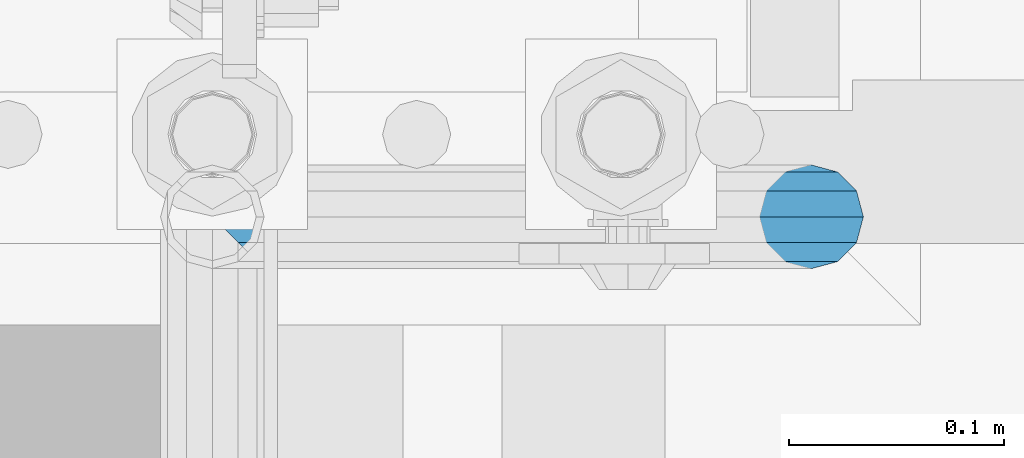
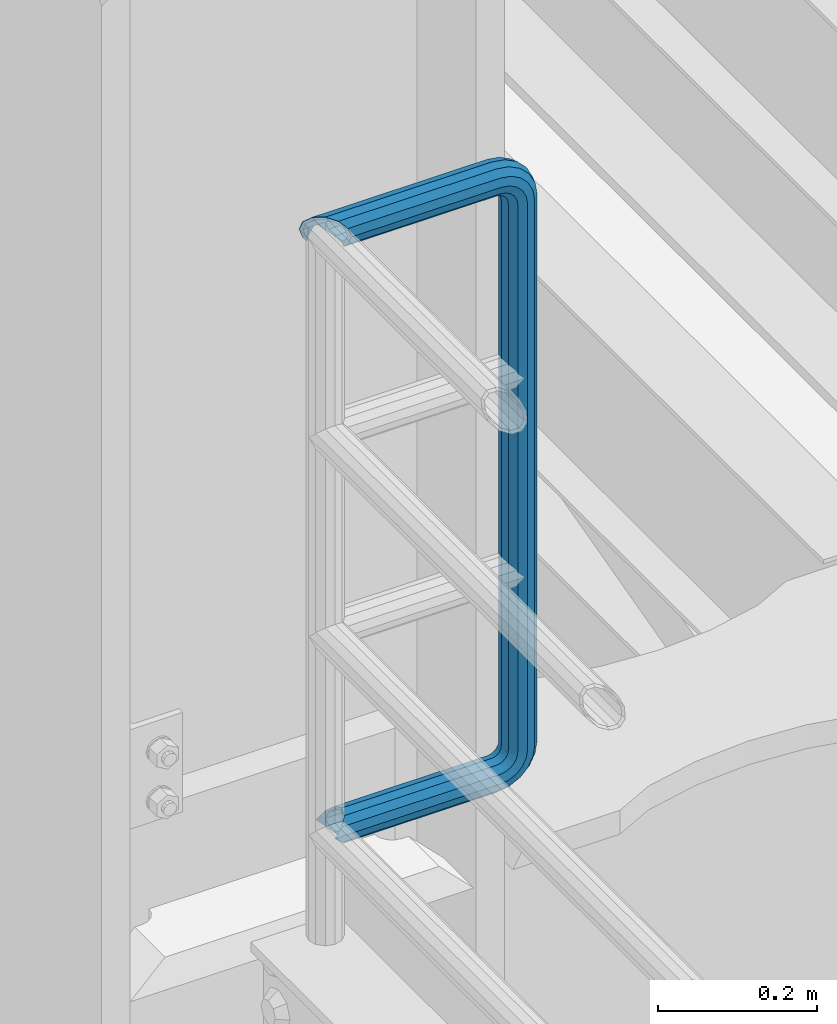
# One storey, part 961 of 1876: 1 beam, 1 element without a shape of its own.
"""IFC2X3 building model written with IfcOpenShell, lengths in millimetres."""

from ifc_helpers import new_model, si_unit, frame, origin_with_axes, place, context, subcontext, project, spatial, faceted_brep, material, type_object, element, aggregate, save


model = new_model("IFC2X3")

# Units and contexts
model_context = context("Model", 3, precision=1e-05, world=origin_with_axes())
body_context = subcontext(model_context, "Body", "Model", "MODEL_VIEW")
ifc_project = project(units=[si_unit("LENGTHUNIT", "METRE", prefix="MILLI"), si_unit("AREAUNIT", "SQUARE_METRE"), si_unit("VOLUMEUNIT", "CUBIC_METRE"), si_unit("MASSUNIT", "GRAM", prefix="KILO"), si_unit("TIMEUNIT", "SECOND"), si_unit("PLANEANGLEUNIT", "RADIAN"), si_unit("SOLIDANGLEUNIT", "STERADIAN"), si_unit("THERMODYNAMICTEMPERATUREUNIT", "DEGREE_CELSIUS"), si_unit("LUMINOUSINTENSITYUNIT", "LUMEN")], contexts=[model_context])

# Site, building, storey
site_placement = place(None, origin_with_axes())
site = spatial("IfcSite", under=ifc_project, at=site_placement, CompositionType="ELEMENT")
building_placement = place(site_placement, origin_with_axes())
building = spatial("IfcBuilding", under=site, at=building_placement, Name="Undefined", CompositionType="ELEMENT")
storey_placement = place(building_placement, origin_with_axes())
storey = spatial("IfcBuildingStorey", under=building, at=storey_placement, Name="Undefined", CompositionType="ELEMENT", Elevation=0.0)

# Assembly, beam
assembly_placement = place(storey_placement, origin_with_axes())
assembly = element("IfcElementAssembly", 1, at=assembly_placement, inside=storey, Name="RAIL", AssemblyPlace="NOTDEFINED", PredefinedType="RIGID_FRAME")
ifc_material = material()
beam_type = type_object("IfcBeamType", Name="PIPE1-1/2SCH40", PredefinedType="NOTDEFINED")
beam_placement = place(assembly_placement, frame((5.00222085975111e-12, -4788.2175, 9229.725), z_axis=(0.0, 0.0, 1.0), x_axis=(1.0, 0.0, 0.0)))
beam = element("IfcBeam", 2, at=beam_placement, type_object=beam_type, material=ifc_material, Name="RAIL", ObjectType="PIPE1-1/2SCH40", context=body_context, shape_type="Brep", body=[
    faceted_brep([(-12.0649999999986, 20.8971929933177, -12.0649999999987), (-12.0649999999986, 20.8971929933186, 0.0), (-12.5151929933171, 20.4470000000001, 0.0), (-15.2545715621367, 17.7076214311801, -10.2235000000001), (-16.4810964966549, 16.4810964966618, -11.4500249345183), (-16.481093238746, 16.4810932387318, -16.4810997545865), (0.0, 24.1299999999992, 0.0), (12.0650000000014, 20.8971929933186, 0.0), (12.5151929933249, 20.4470000000001, 0.0), (12.0650000000064, 20.8971929933177, -12.0649999999987), (15.2545715621445, 17.7076214311801, -10.2235000000001), (20.8971929933249, 12.0650000000005, -20.8971929933177), (20.8971929933249, 12.0650000000005, -15.8661214311796), (20.8971929933249, -12.0650000000005, -15.8661214311796), (20.8971929933249, -12.0650000000005, -20.8971929933177), (16.4810997545745, -16.4810997545883, -16.48109323873), (16.4810964966636, -16.4810964966564, -11.4500249345256), (24.1300000000063, 0.0, -20.4470000000001), (24.1300000000063, 0.0, -24.130000000001), (21.3906214311868, -10.2235000000001, -17.7076214311819), (21.3906214311868, 10.2235000000001, -17.7076214311819), (1.20714750983051e-12, 24.1299999999974, -914.399963378906), (12.0650000000014, 20.8971929933159, -926.464963378905), (12.0650000000014, 20.8971929933177, -902.334963378908), (12.0650000000014, -20.8971929933195, -902.334963378908), (12.0650000000014, -20.8971929933195, -926.464963378905), (1.52133659548828e-12, -24.130000000001, -914.399963378906), (20.8971929933199, -12.0650000000023, -893.502770385589), (20.8971929933199, -12.0650000000005, -898.533841947723), (15.2545715621378, -17.7076214311819, -904.176463378906), (12.5151929933181, -20.4470000000019, -914.399963378906), (15.2545715621376, -17.7076214311819, -924.623463378906), (20.8971929933199, -12.0650000000005, -930.26608481009), (20.8971929933199, -12.0650000000023, -935.297156372224), (24.1300000000014, -1.81898940354586e-12, -934.846963378906), (24.1300000000014, -1.81898940354586e-12, -938.529963378907), (21.3906214311813, -10.2235000000019, -932.107584810088), (21.3906214311823, 10.2234999999982, -932.107584810088), (20.8971929933199, 12.0650000000005, -930.266084810086), (20.8971929933199, 12.0649999999987, -935.297156372224), (15.2545715621413, 17.7076214311783, -924.623463378906), (12.5151929933216, 20.4469999999983, -914.399963378906), (15.2545715621411, 17.7076214311783, -904.176463378906), (20.8971929933199, 12.0650000000005, -898.533841947727), (20.8971929933199, 12.0649999999987, -893.502770385589), (21.3906214311822, 10.2234999999982, -896.692341947724), (24.1300000000014, 0.0, -893.952963378906), (24.1300000000014, 0.0, -890.269963378905), (21.3906214311814, -10.2235000000019, -896.692341947724), (241.299995422363, -20.8971929933177, -12.0649999999987), (241.299995422363, -12.0650000000005, -20.8971929933177), (246.615954666858, -12.0650000000005, -21.7391582230448), (249.345252399393, -20.8971929933177, -13.3392435235728), (241.299995422363, -24.1299999999992, 0.0), (253.073542436527, -24.1299999999992, -1.86474665447167), (241.299995422363, -20.8971929933177, 12.0649999999987), (256.801832473661, -20.8971929933177, 9.60975021462946), (241.299995422363, -12.0650000000005, 20.8971929933177), (259.531130206197, -12.0650000000005, 18.0096649141014), (241.299995422363, 0.0, 24.130000000001), (260.530122510796, 0.0, 21.084247083727), (241.299995422363, 12.0650000000005, 20.8971929933177), (259.531130206197, 12.0650000000005, 18.0096649141014), (241.299995422363, 20.8971929933177, 12.0649999999987), (256.801832473661, 20.8971929933177, 9.60975021462946), (241.299995422363, 24.1299999999992, 0.0), (253.073542436527, 24.1299999999992, -1.86474665447167), (241.299995422363, 20.8971929933177, -12.0649999999987), (249.345252399393, 20.8971929933177, -13.3392435235728), (241.299995422363, 12.0650000000005, -20.8971929933177), (246.615954666858, 12.0650000000005, -21.7391582230448), (241.299995422363, 0.0, -24.130000000001), (245.616962362259, 0.0, -24.8137403926739), (291.464993896486, 20.8971929933177, -38.0999984741211), (300.297186889804, 12.0650000000005, -38.0999984741211), (300.297186889803, 12.0650000000005, -876.299964904785), (291.464993896484, 20.8971929933177, -876.299964904785), (303.529993896486, 0.0, -38.0999984741211), (303.529993896484, 0.0, -876.299964904785), (300.297186889804, -12.0650000000005, -38.0999984741211), (300.297186889803, -12.0650000000005, -876.299964904785), (291.464993896486, -20.8971929933177, -38.0999984741211), (291.464993896484, -20.8971929933177, -876.299964904785), (279.399993896484, -24.1299999999992, -38.0999984741211), (279.399993896484, -24.1299999999992, -876.299964904785), (267.334993896485, -20.8971929933177, -38.0999984741211), (267.334993896484, -20.8971929933177, -876.299964904785), (258.502800903167, -12.0650000000005, -38.0999984741211), (258.502800903166, -12.0650000000005, -876.299964904785), (255.269993896485, 0.0, -38.0999984741211), (255.269993896484, 0.0, -876.299964904785), (258.502800903167, 12.0650000000005, -38.0999984741211), (258.502800903166, 12.0650000000005, -876.299964904785), (267.334993896485, 20.8971929933177, -38.0999984741211), (267.334993896484, 20.8971929933177, -876.299964904785), (279.399993896485, 24.1299999999992, -38.0999984741211), (279.399993896484, 24.1299999999992, -876.299964904785), (277.535247242011, 24.1299999999992, -888.073511918952), (266.06075037291, 20.8971929933177, -884.345221881817), (257.660835673438, 12.0650000000005, -881.615924149282), (254.586253503809, 0.0, -880.616931844681), (257.660835673438, -12.0650000000005, -881.615924149282), (266.06075037291, -20.8971929933177, -884.345221881817), (277.535247242011, -24.130000000001, -888.073511918952), (289.009744111112, -20.8971929933195, -891.801801956084), (297.409658810584, -12.0650000000005, -894.531099688622), (300.484240980214, 0.0, -895.53009199322), (297.409658810584, 12.0650000000005, -894.531099688622), (289.009744111112, 20.8971929933177, -891.801801956084), (241.299995422364, -20.8971929933195, -926.464963378909), (241.299995422363, -24.130000000001, -914.399963378906), (241.299995422363, -20.8971929933195, -902.334963378908), (241.299995422363, -12.0650000000005, -893.502770385589), (241.299995422363, 0.0, -890.269963378909), (241.299995422364, -1.81898940354586e-12, -938.529963378911), (241.299995422364, -12.0650000000005, -935.297156372228), (241.299995422364, 12.0649999999987, -935.297156372228), (241.299995422364, 20.8971929933177, -926.464963378909), (241.299995422364, 24.1299999999992, -914.39996337891), (241.299995422363, 20.8971929933177, -902.334963378908), (241.299995422363, 12.0649999999987, -893.502770385589), (256.801832473666, -20.8971929933195, -924.009713593536), (259.531130206201, -12.0650000000005, -932.409628293008), (253.07354243653, -24.130000000001, -912.535216724435), (249.345252399395, -20.8971929933195, -901.060719855333), (246.615954666859, -12.0650000000005, -892.660805155861), (245.61696236226, 0.0, -889.586222986232), (246.615954666859, 12.0649999999987, -892.660805155861), (249.345252399395, 20.8971929933177, -901.060719855333), (253.07354243653, 24.1299999999992, -912.535216724435), (256.801832473666, 20.8971929933177, -924.009713593536), (259.531130206202, 12.0649999999987, -932.409628293008), (260.530122510801, 0.0, -935.484210462637), (275.977674493608, -12.0650000000005, -924.029695422334), (277.877870775644, 0.0, -926.645091230272), (270.786241706733, -20.8971929933195, -916.884301193139), (263.694612637823, -24.130000000001, -907.123511156005), (256.602983568912, -20.8971929933195, -897.362721118872), (251.411550782037, -12.0650000000005, -890.21732688968), (249.511354500001, 0.0, -887.601931081743), (251.411550782037, 12.0650000000005, -890.21732688968), (256.602983568912, 20.8971929933177, -897.362721118872), (263.694612637823, 24.1299999999992, -907.123511156005), (270.786241706733, 20.8971929933177, -916.884301193139), (275.977674493594, 12.0649999999987, -924.029695422345), (291.645121747852, 0.0, -912.877840258065), (289.029725939912, 12.0650000000005, -910.977643976028), (289.029725939912, -12.0650000000005, -910.977643976028), (281.884331710718, -20.8971929933195, -905.786211189152), (272.123541673585, -24.130000000001, -898.694582120243), (262.362751636451, -20.8971929933195, -891.602953051333), (255.217357407258, -12.0650000000005, -886.411520264461), (252.601961599318, 0.0, -884.511323982424), (255.217357407258, 12.0650000000005, -886.411520264461), (262.362751636451, 20.8971929933177, -891.602953051333), (272.123541673585, 24.1299999999992, -898.694582120243), (281.884331710718, 20.8971929933177, -905.786211189152), (289.009744111112, 20.8971929933177, -22.5981614228222), (277.535247242011, 24.1299999999992, -26.3264514599541), (297.409658810584, 12.0650000000005, -19.8688636902843), (300.484240980213, 0.0, -18.8698713856866), (297.409658810584, -12.0650000000005, -19.8688636902843), (289.009744111112, -20.8971929933177, -22.5981614228222), (277.535247242011, -24.1299999999992, -26.3264514599541), (266.060750372911, -20.8971929933177, -30.0547414970897), (257.660835673439, -12.0650000000005, -32.7840392296275), (254.58625350381, 0.0, -33.7830315342253), (257.660835673439, 12.0650000000005, -32.7840392296275), (266.060750372911, 20.8971929933177, -30.0547414970897), (272.123541673583, 24.1299999999992, -15.7053812586601), (262.362751636451, 20.8971929933177, -22.7970103275729), (281.884331710716, 20.8971929933177, -8.61375218975081), (289.029725939909, 12.0650000000005, -3.42231940287456), (291.645121747848, 0.0, -1.52212312084157), (289.029725939909, -12.0650000000005, -3.42231940287456), (281.884331710716, -20.8971929933177, -8.61375218975081), (272.123541673583, -24.1299999999992, -15.7053812586601), (262.362751636451, -20.8971929933177, -22.7970103275729), (255.217357407257, -12.0650000000005, -27.9884431144455), (252.601961599318, 0.0, -29.8886393964822), (255.217357407257, 12.0650000000005, -27.9884431144455), (256.602983568912, 20.8971929933177, -17.037242260034), (251.411550782037, 12.0650000000005, -24.1826364892258), (263.694612637822, 24.1299999999992, -7.27645222290084), (270.786241706732, 20.8971929933177, 2.48433781423228), (275.977674493607, 12.0650000000005, 9.62973204342416), (277.877870775642, 0.0, 12.2451278513654), (275.977674493607, -12.0650000000005, 9.62973204342416), (270.786241706732, -20.8971929933177, 2.48433781423228), (263.694612637822, -24.1299999999992, -7.27645222290084), (256.602983568912, -20.8971929933177, -17.037242260034), (251.411550782037, -12.0650000000005, -24.1826364892258), (249.511354500002, 0.0, -26.7980322971671), (-20.897192993333, 20.8971929933177, -12.0649999999987), (-24.1300000000145, 24.1299999999992, 0.0), (-20.897192993333, 20.8971929933177, 12.0649999999987), (-12.0650000000145, 12.0650000000005, 20.8971929933177), (-1.45519152283669e-11, 0.0, 24.130000000001), (12.0649999999854, -12.0650000000005, 20.8971929933177), (20.8971929933039, -20.8971929933177, 12.0649999999987), (24.1299999999854, -24.1299999999992, 0.0), (20.8971929933039, -20.8971929933177, -12.0649999999987), (241.299995422363, -17.7076214311801, 10.2235000000001), (241.299995422363, -20.4470000000001, 0.0), (20.4469999999854, -20.4470000000001, 0.0), (17.7076214311658, -17.7076214311801, 10.2235000000001), (241.299995422363, -17.7076214311801, -10.2235000000001), (17.7076214311658, -17.7076214311801, -10.2235000000001), (241.299995422363, -10.2235000000001, -17.7076214311819), (241.299995422363, 0.0, -20.4470000000001), (241.299995422363, 0.0, 20.4470000000001), (241.299995422363, -10.2235000000001, 17.7076214311819), (10.2234999999854, -10.2235000000001, 17.7076214311819), (-1.45519152283669e-11, 0.0, 20.4470000000001), (241.299995422363, 10.2235000000001, 17.7076214311819), (-10.2235000000145, 10.2235000000001, 17.7076214311819), (241.299995422363, 17.7076214311801, 10.2235000000001), (-17.7076214311949, 17.7076214311801, 10.2235000000001), (-17.7076214311949, 17.7076214311801, -10.2235000000001), (-20.4470000000145, 20.4470000000001, 0.0), (241.299995422363, 20.4470000000001, 0.0), (241.299995422363, 17.7076214311801, -10.2235000000001), (241.299995422363, 10.2235000000001, -17.7076214311819), (258.545498388721, -10.2235000000001, 14.9762020957387), (256.23277767852, -17.7076214311801, 7.85837963987069), (253.073542436527, -20.4470000000001, -1.86474665447167), (249.914307194535, -17.7076214311801, -11.5878729488177), (247.601586484334, -10.2235000000001, -18.7056954046857), (246.755071952542, 0.0, -21.31099924316), (247.601586484334, 10.2235000000001, -18.7056954046857), (249.914307194535, 17.7076214311801, -11.5878729488177), (253.073542436527, 20.4470000000001, -1.86474665447167), (256.23277767852, 17.7076214311801, 7.85837963987069), (258.545498388721, 10.2235000000001, 14.9762020957387), (259.392012920513, 0.0, 17.5815059342131), (275.713057691449, 0.0, 9.26551826108334), (274.10289136825, -10.2235000000001, 7.04931444488102), (274.10289136825, 10.2235000000001, 7.04931444488102), (269.703835164635, 17.7076214311801, 0.994533019089431), (263.694612637822, 20.4470000000001, -7.27645222290084), (257.685390111009, 17.7076214311801, -15.5474374648911), (253.286333907394, 10.2235000000001, -21.6022188906827), (251.676167584195, 0.0, -23.818422706885), (253.286333907394, -10.2235000000001, -21.6022188906827), (257.685390111009, -17.7076214311801, -15.5474374648911), (263.694612637822, -20.4470000000001, -7.27645222290084), (269.703835164635, -17.7076214311801, 0.994533019089431), (286.449308341364, -10.2235000000001, -5.29710252823133), (280.394526915574, -17.7076214311801, -9.69615873184739), (288.665512157566, 0.0, -3.68693620503473), (286.449308341364, 10.2235000000001, -5.29710252823133), (280.394526915574, 17.7076214311801, -9.69615873184739), (272.123541673583, 20.4470000000001, -15.7053812586601), (263.852556431592, 17.7076214311801, -21.7146037854764), (257.797775005802, 10.2235000000001, -26.1136599890888), (255.581571189601, 0.0, -27.723826312289), (257.797775005802, -10.2235000000001, -26.1136599890888), (263.852556431592, -17.7076214311801, -21.7146037854764), (272.123541673583, -20.4470000000001, -15.7053812586601), (287.258373536355, -17.7076214311801, -23.1672162179639), (277.535247242011, -20.4470000000001, -26.3264514599541), (294.376195992223, -10.2235000000001, -20.8544955077632), (296.981499830698, 0.0, -20.00798097597), (294.376195992223, 10.2235000000001, -20.8544955077632), (287.258373536355, 17.7076214311801, -23.1672162179639), (277.535247242011, 20.4470000000001, -26.3264514599541), (267.812120947668, 17.7076214311801, -29.485686701948), (260.6942984918, 10.2235000000001, -31.7984074121487), (258.088994653325, 0.0, -32.6449219439419), (260.6942984918, -10.2235000000001, -31.7984074121487), (267.812120947668, -17.7076214311801, -29.485686701948), (279.399993896484, -20.4470000000001, -38.0999984741211), (269.176493896485, -17.7076214311801, -38.0999984741211), (289.623493896486, -17.7076214311801, -38.0999984741211), (297.107615327666, -10.2235000000001, -38.0999984741211), (299.846993896486, 0.0, -38.0999984741211), (297.107615327666, 10.2235000000001, -38.0999984741211), (289.623493896486, 17.7076214311801, -38.0999984741211), (279.399993896485, 20.4470000000001, -38.0999984741211), (269.176493896485, 17.7076214311801, -38.0999984741211), (261.692372465305, 10.2235000000001, -38.0999984741211), (258.952993896485, 0.0, -38.0999984741211), (261.692372465305, -10.2235000000001, -38.0999984741211), (269.176493896484, -17.7076214311801, -876.299964904785), (261.692372465304, -10.2235000000001, -876.299964904785), (258.952993896484, 0.0, -876.299964904785), (261.692372465304, 10.2235000000001, -876.299964904785), (269.176493896484, 17.7076214311801, -876.299964904785), (279.399993896484, 20.4470000000001, -876.299964904785), (289.623493896484, 17.7076214311801, -876.299964904785), (297.107615327665, 10.2235000000001, -876.299964904785), (299.846993896484, 0.0, -876.299964904785), (297.107615327665, -10.2235000000001, -876.299964904785), (289.623493896484, -17.7076214311801, -876.299964904785), (279.399993896484, -20.4470000000001, -876.299964904785), (277.535247242011, -20.4470000000001, -888.073511918952), (267.812120947667, -17.7076214311801, -884.914276676958), (260.694298491799, -10.2235000000001, -882.601555966758), (258.088994653324, 0.0, -881.755041434964), (260.694298491799, 10.2235000000001, -882.601555966758), (267.812120947668, 17.7076214311801, -884.914276676958), (277.535247242011, 20.4470000000001, -888.073511918952), (287.258373536355, 17.7076214311801, -891.232747160942), (294.376195992223, 10.2235000000001, -893.545467871143), (296.981499830699, 0.0, -894.391982402936), (294.376195992223, -10.2235000000001, -893.545467871143), (287.258373536355, -17.7076214311801, -891.232747160942), (280.394526915577, -17.7076214311801, -904.703804647055), (272.123541673585, -20.4470000000001, -898.694582120243), (286.449308341367, -10.2235000000001, -909.102860850671), (288.665512157569, 0.0, -910.713027173868), (286.449308341367, 10.2235000000001, -909.102860850671), (280.394526915577, 17.7076214311801, -904.703804647055), (272.123541673585, 20.4470000000001, -898.694582120243), (263.852556431593, 17.7076214311801, -892.68535959343), (257.797775005802, 10.2235000000001, -888.286303389817), (255.581571189601, 0.0, -886.676137066617), (257.797775005802, -10.2235000000001, -888.286303389817), (263.852556431593, -17.7076214311801, -892.68535959343), (263.694612637823, -20.4470000000001, -907.123511156005), (257.685390111009, -17.7076214311801, -898.852525914015), (269.703835164636, -17.7076214311801, -915.394496397999), (274.102891368238, -10.2235000000001, -921.449277823798), (275.71305769145, 0.0, -923.66548163999), (274.102891368251, 10.2235000000001, -921.449277823787), (269.703835164636, 17.7076214311801, -915.394496397999), (263.694612637823, 20.4470000000001, -907.123511156005), (257.685390111009, 17.7076214311801, -898.852525914015), (253.286333907394, 10.2235000000001, -892.797744488227), (251.676167584195, 0.0, -890.581540672025), (253.286333907394, -10.2235000000001, -892.797744488227), (249.914307194537, -17.7076214311801, -902.812090430092), (247.601586484335, -10.2235000000001, -895.694267974224), (253.07354243653, -20.4470000000001, -912.535216724435), (256.232777678524, -17.7076214311819, -922.258343018777), (258.545498388725, -10.2235000000001, -929.376165474645), (259.392012920517, 0.0, -931.981469313119), (258.545498388725, 10.2235000000001, -929.376165474645), (256.232777678524, 17.7076214311801, -922.258343018777), (253.07354243653, 20.4470000000001, -912.535216724435), (249.914307194537, 17.7076214311801, -902.812090430092), (247.601586484335, 10.2235000000001, -895.694267974224), (246.755071952543, 0.0, -893.088964135746), (241.299995422363, -10.2235000000001, -896.692341947728), (241.299995422363, 0.0, -893.95296337891), (241.299995422363, -17.7076214311819, -904.17646337891), (241.299995422363, -20.4470000000001, -914.399963378906), (241.299995422364, -17.7076214311819, -924.62346337891), (241.299995422364, -10.2235000000001, -932.107584810088), (241.299995422364, -1.81898940354586e-12, -934.84696337891), (241.299995422364, 10.2234999999982, -932.107584810088), (241.299995422364, 17.7076214311801, -924.62346337891), (241.299995422364, 20.4470000000001, -914.39996337891), (241.299995422363, 17.7076214311801, -904.17646337891), (241.299995422363, 10.2235000000001, -896.692341947728)], [[[0, 1, 2, 3, 4, 5]], [[6, 1, 0]], [[2, 1, 6, 7, 8]], [[9, 7, 6]], [[10, 8, 7, 9, 11, 12]], [[13, 14, 15, 16]], [[17, 18, 14, 13, 19]], [[20, 12, 11, 18, 17]], [[21, 22, 23]], [[24, 25, 26]], [[27, 28, 29, 30, 31, 32, 33, 25, 24]], [[34, 35, 33, 32, 36]], [[37, 38, 39, 35, 34]], [[23, 22, 39, 38, 40, 41, 42, 43, 44]], [[44, 43, 45, 46, 47]], [[47, 46, 48, 28, 27]], [[49, 50, 51, 52]], [[53, 49, 52, 54]], [[55, 53, 54, 56]], [[57, 55, 56, 58]], [[59, 57, 58, 60]], [[61, 59, 60, 62]], [[63, 61, 62, 64]], [[65, 63, 64, 66]], [[67, 65, 66, 68]], [[69, 67, 68, 70]], [[71, 69, 70, 72]], [[73, 74, 75, 76]], [[74, 77, 78, 75]], [[77, 79, 80, 78]], [[79, 81, 82, 80]], [[81, 83, 84, 82]], [[83, 85, 86, 84]], [[85, 87, 88, 86]], [[87, 89, 90, 88]], [[89, 91, 92, 90]], [[91, 93, 94, 92]], [[93, 95, 96, 94]], [[94, 96, 97, 98]], [[92, 94, 98, 99]], [[90, 92, 99, 100]], [[88, 90, 100, 101]], [[86, 88, 101, 102]], [[84, 86, 102, 103]], [[82, 84, 103, 104]], [[80, 82, 104, 105]], [[78, 80, 105, 106]], [[75, 78, 106, 107]], [[76, 75, 107, 108]], [[109, 110, 26, 25]], [[110, 111, 24, 26]], [[111, 112, 27, 24]], [[112, 113, 47, 27]], [[114, 115, 33, 35]], [[116, 114, 35, 39]], [[117, 116, 39, 22]], [[118, 117, 22, 21]], [[119, 118, 21, 23]], [[120, 119, 23, 44]], [[113, 120, 44, 47]], [[115, 109, 25, 33]], [[121, 109, 115, 122]], [[123, 110, 109, 121]], [[124, 111, 110, 123]], [[125, 112, 111, 124]], [[126, 113, 112, 125]], [[127, 120, 113, 126]], [[128, 119, 120, 127]], [[129, 118, 119, 128]], [[130, 117, 118, 129]], [[131, 116, 117, 130]], [[132, 114, 116, 131]], [[122, 115, 114, 132]], [[133, 122, 132, 134]], [[135, 121, 122, 133]], [[136, 123, 121, 135]], [[137, 124, 123, 136]], [[138, 125, 124, 137]], [[139, 126, 125, 138]], [[140, 127, 126, 139]], [[141, 128, 127, 140]], [[142, 129, 128, 141]], [[143, 130, 129, 142]], [[144, 131, 130, 143]], [[134, 132, 131, 144]], [[145, 134, 144, 146]], [[147, 133, 134, 145]], [[148, 135, 133, 147]], [[149, 136, 135, 148]], [[150, 137, 136, 149]], [[151, 138, 137, 150]], [[152, 139, 138, 151]], [[153, 140, 139, 152]], [[154, 141, 140, 153]], [[155, 142, 141, 154]], [[156, 143, 142, 155]], [[146, 144, 143, 156]], [[107, 146, 156, 108]], [[106, 145, 146, 107]], [[105, 147, 145, 106]], [[104, 148, 147, 105]], [[103, 149, 148, 104]], [[102, 150, 149, 103]], [[101, 151, 150, 102]], [[100, 152, 151, 101]], [[99, 153, 152, 100]], [[98, 154, 153, 99]], [[97, 155, 154, 98]], [[108, 156, 155, 97]], [[96, 76, 108, 97]], [[95, 73, 76, 96]], [[157, 73, 95, 158]], [[159, 74, 73, 157]], [[160, 77, 74, 159]], [[161, 79, 77, 160]], [[162, 81, 79, 161]], [[163, 83, 81, 162]], [[164, 85, 83, 163]], [[165, 87, 85, 164]], [[166, 89, 87, 165]], [[167, 91, 89, 166]], [[168, 93, 91, 167]], [[158, 95, 93, 168]], [[169, 158, 168, 170]], [[171, 157, 158, 169]], [[172, 159, 157, 171]], [[173, 160, 159, 172]], [[174, 161, 160, 173]], [[175, 162, 161, 174]], [[176, 163, 162, 175]], [[177, 164, 163, 176]], [[178, 165, 164, 177]], [[179, 166, 165, 178]], [[180, 167, 166, 179]], [[170, 168, 167, 180]], [[181, 170, 180, 182]], [[183, 169, 170, 181]], [[184, 171, 169, 183]], [[185, 172, 171, 184]], [[186, 173, 172, 185]], [[187, 174, 173, 186]], [[188, 175, 174, 187]], [[189, 176, 175, 188]], [[190, 177, 176, 189]], [[191, 178, 177, 190]], [[192, 179, 178, 191]], [[182, 180, 179, 192]], [[70, 182, 192, 72]], [[68, 181, 182, 70]], [[66, 183, 181, 68]], [[64, 184, 183, 66]], [[62, 185, 184, 64]], [[60, 186, 185, 62]], [[58, 187, 186, 60]], [[56, 188, 187, 58]], [[54, 189, 188, 56]], [[52, 190, 189, 54]], [[51, 191, 190, 52]], [[72, 192, 191, 51]], [[50, 71, 72, 51]], [[71, 50, 14, 18]], [[69, 71, 18, 11]], [[67, 69, 11, 9]], [[65, 67, 9, 6]], [[193, 0, 5]], [[193, 194, 6, 0]], [[63, 65, 6, 194, 195]], [[61, 63, 195, 196]], [[59, 61, 196, 197]], [[57, 59, 197, 198]], [[55, 57, 198, 199]], [[53, 55, 199, 200]], [[49, 53, 200, 201]], [[50, 49, 201, 15, 14]], [[202, 203, 204, 205]], [[203, 206, 207, 204]], [[16, 207, 206, 208, 19, 13]], [[208, 209, 17, 19]], [[210, 211, 212, 213]], [[214, 210, 213, 215]], [[216, 214, 215, 217]], [[218, 4, 3]], [[219, 218, 3, 2]], [[220, 216, 217, 219, 2, 8]], [[221, 220, 8, 10]], [[222, 221, 10, 12, 20]], [[209, 222, 20, 17]], [[201, 200, 199, 198, 197, 196, 195, 194, 193, 5, 4, 218, 219, 217, 215, 213, 212, 205, 204, 207, 16, 15]], [[211, 202, 205, 212]], [[202, 211, 223, 224]], [[203, 202, 224, 225]], [[206, 203, 225, 226]], [[208, 206, 226, 227]], [[209, 208, 227, 228]], [[222, 209, 228, 229]], [[221, 222, 229, 230]], [[220, 221, 230, 231]], [[216, 220, 231, 232]], [[214, 216, 232, 233]], [[210, 214, 233, 234]], [[211, 210, 234, 223]], [[234, 235, 236, 223]], [[233, 237, 235, 234]], [[232, 238, 237, 233]], [[231, 239, 238, 232]], [[230, 240, 239, 231]], [[229, 241, 240, 230]], [[228, 242, 241, 229]], [[227, 243, 242, 228]], [[226, 244, 243, 227]], [[225, 245, 244, 226]], [[224, 246, 245, 225]], [[223, 236, 246, 224]], [[236, 247, 248, 246]], [[235, 249, 247, 236]], [[237, 250, 249, 235]], [[238, 251, 250, 237]], [[239, 252, 251, 238]], [[240, 253, 252, 239]], [[241, 254, 253, 240]], [[242, 255, 254, 241]], [[243, 256, 255, 242]], [[244, 257, 256, 243]], [[245, 258, 257, 244]], [[246, 248, 258, 245]], [[248, 259, 260, 258]], [[247, 261, 259, 248]], [[249, 262, 261, 247]], [[250, 263, 262, 249]], [[251, 264, 263, 250]], [[252, 265, 264, 251]], [[253, 266, 265, 252]], [[254, 267, 266, 253]], [[255, 268, 267, 254]], [[256, 269, 268, 255]], [[257, 270, 269, 256]], [[258, 260, 270, 257]], [[260, 271, 272, 270]], [[259, 273, 271, 260]], [[261, 274, 273, 259]], [[262, 275, 274, 261]], [[263, 276, 275, 262]], [[264, 277, 276, 263]], [[265, 278, 277, 264]], [[266, 279, 278, 265]], [[267, 280, 279, 266]], [[268, 281, 280, 267]], [[269, 282, 281, 268]], [[270, 272, 282, 269]], [[282, 272, 283, 284]], [[281, 282, 284, 285]], [[280, 281, 285, 286]], [[279, 280, 286, 287]], [[278, 279, 287, 288]], [[277, 278, 288, 289]], [[276, 277, 289, 290]], [[275, 276, 290, 291]], [[274, 275, 291, 292]], [[273, 274, 292, 293]], [[271, 273, 293, 294]], [[272, 271, 294, 283]], [[283, 294, 295, 296]], [[284, 283, 296, 297]], [[285, 284, 297, 298]], [[286, 285, 298, 299]], [[287, 286, 299, 300]], [[288, 287, 300, 301]], [[289, 288, 301, 302]], [[290, 289, 302, 303]], [[291, 290, 303, 304]], [[292, 291, 304, 305]], [[293, 292, 305, 306]], [[294, 293, 306, 295]], [[306, 307, 308, 295]], [[305, 309, 307, 306]], [[304, 310, 309, 305]], [[303, 311, 310, 304]], [[302, 312, 311, 303]], [[301, 313, 312, 302]], [[300, 314, 313, 301]], [[299, 315, 314, 300]], [[298, 316, 315, 299]], [[297, 317, 316, 298]], [[296, 318, 317, 297]], [[295, 308, 318, 296]], [[308, 319, 320, 318]], [[307, 321, 319, 308]], [[309, 322, 321, 307]], [[310, 323, 322, 309]], [[311, 324, 323, 310]], [[312, 325, 324, 311]], [[313, 326, 325, 312]], [[314, 327, 326, 313]], [[315, 328, 327, 314]], [[316, 329, 328, 315]], [[317, 330, 329, 316]], [[318, 320, 330, 317]], [[320, 331, 332, 330]], [[319, 333, 331, 320]], [[321, 334, 333, 319]], [[322, 335, 334, 321]], [[323, 336, 335, 322]], [[324, 337, 336, 323]], [[325, 338, 337, 324]], [[326, 339, 338, 325]], [[327, 340, 339, 326]], [[328, 341, 340, 327]], [[329, 342, 341, 328]], [[330, 332, 342, 329]], [[332, 343, 344, 342]], [[331, 345, 343, 332]], [[333, 346, 345, 331]], [[334, 347, 346, 333]], [[335, 348, 347, 334]], [[336, 349, 348, 335]], [[337, 350, 349, 336]], [[338, 351, 350, 337]], [[339, 352, 351, 338]], [[340, 353, 352, 339]], [[341, 354, 353, 340]], [[342, 344, 354, 341]], [[354, 344, 46, 45]], [[42, 353, 354, 45, 43]], [[352, 353, 42, 41]], [[351, 352, 41, 40]], [[350, 351, 40, 38, 37]], [[349, 350, 37, 34]], [[348, 349, 34, 36]], [[31, 347, 348, 36, 32]], [[346, 347, 31, 30]], [[345, 346, 30, 29]], [[343, 345, 29, 28, 48]], [[344, 343, 48, 46]]]),
])
aggregate(assembly, [beam])

save(model, "model.ifc")
